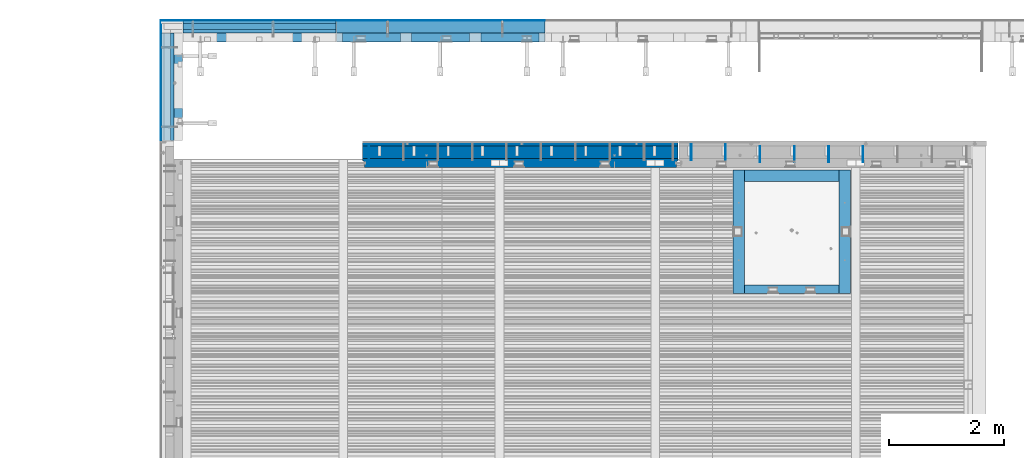
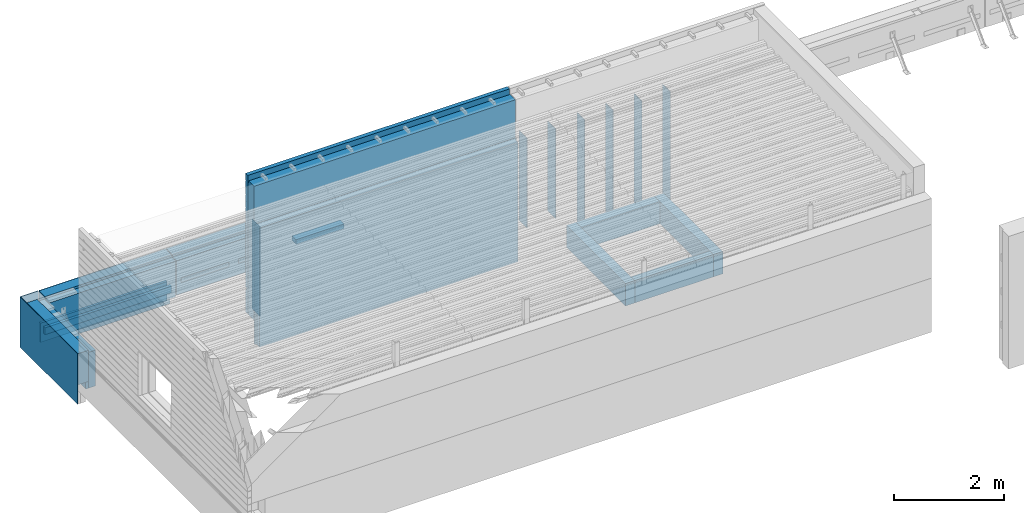
# One storey, part 79 of 153: 31 walls, 10 elements without a shape of their own.
"""IFC2X3 building model written with IfcOpenShell, lengths in millimetres."""

from ifc_helpers import new_model, si_unit, frame, origin_with_axes, place, context, subcontext, project, spatial, faceted_brep, material, type_object, element, aggregate, save


model = new_model("IFC2X3")

# Units and contexts
model_context = context("Model", 3, precision=1e-05, world=origin_with_axes())
body_context = subcontext(model_context, "Body", "Model", "MODEL_VIEW")
ifc_project = project(units=[si_unit("LENGTHUNIT", "METRE", prefix="MILLI"), si_unit("AREAUNIT", "SQUARE_METRE"), si_unit("VOLUMEUNIT", "CUBIC_METRE"), si_unit("MASSUNIT", "GRAM", prefix="KILO"), si_unit("TIMEUNIT", "SECOND"), si_unit("PLANEANGLEUNIT", "RADIAN"), si_unit("SOLIDANGLEUNIT", "STERADIAN"), si_unit("THERMODYNAMICTEMPERATUREUNIT", "DEGREE_CELSIUS"), si_unit("LUMINOUSINTENSITYUNIT", "LUMEN")], contexts=[model_context])

# Site, building, storey
site_placement = place(None, origin_with_axes())
site = spatial("IfcSite", under=ifc_project, at=site_placement, CompositionType="ELEMENT")
building_placement = place(site_placement, origin_with_axes())
building = spatial("IfcBuilding", under=site, at=building_placement, CompositionType="ELEMENT")
storey_placement = place(building_placement, origin_with_axes())
storey = spatial("IfcBuildingStorey", under=building, at=storey_placement, Name="8", CompositionType="ELEMENT", Elevation=0.0)

# Assembly, walls
assembly_1_placement = place(storey_placement, origin_with_axes())
assembly_1 = element("IfcElementAssembly", 1, at=assembly_1_placement, inside=storey, AssemblyPlace="NOTDEFINED", PredefinedType="REINFORCEMENT_UNIT")
ifc_material_1 = material(Name="Undefined")
wall_type_1 = type_object("IfcWallType", PredefinedType="NOTDEFINED")
wall_1_placement = place(assembly_1_placement, frame((19880.0500042038, 20799.9500000001, 104075.0), z_axis=(0.0, 0.0, 1.0), x_axis=(0.0, -1.0, 0.0)))
wall_1 = element("IfcWall", 2, at=wall_1_placement, type_object=wall_type_1, material=ifc_material_1, Name="(PD)", context=body_context, shape_type="Brep", body=[
    faceted_brep([(0.0, 5.0, -1265.0), (0.0, 5.0, 1265.0), (280.000000000011, 5.0, 1265.0), (280.000000000011, 5.0, -1265.0), (0.0, -5.0, 1265.0), (280.000000000011, -5.0, 1265.0), (0.0, -5.0, -1265.0), (280.000000000011, -5.0, -1265.0)], [[[0, 1, 2, 3]], [[1, 4, 5, 2]], [[4, 6, 7, 5]], [[6, 0, 3, 7]], [[5, 7, 3, 2]], [[6, 4, 1, 0]]]),
])
wall_2_placement = place(assembly_1_placement, frame((19280.0500042038, 20799.9500000001, 104075.0), z_axis=(0.0, 0.0, 1.0), x_axis=(0.0, -1.0, 0.0)))
wall_2 = element("IfcWall", 3, at=wall_2_placement, type_object=wall_type_1, material=ifc_material_1, Name="(PD)", context=body_context, shape_type="Brep", body=[
    faceted_brep([(0.0, 5.0, -1265.0), (0.0, 5.0, 1265.0), (280.000000000011, 5.0, 1265.0), (280.000000000011, 5.0, -1265.0), (0.0, -5.0, 1265.0), (280.000000000011, -5.0, 1265.0), (0.0, -5.0, -1265.0), (280.000000000011, -5.0, -1265.0)], [[[0, 1, 2, 3]], [[1, 4, 5, 2]], [[4, 6, 7, 5]], [[6, 0, 3, 7]], [[5, 7, 3, 2]], [[6, 4, 1, 0]]]),
])
wall_3_placement = place(assembly_1_placement, frame((18680.0500042038, 20799.9500000001, 104075.0), z_axis=(0.0, 0.0, 1.0), x_axis=(0.0, -1.0, 0.0)))
wall_3 = element("IfcWall", 4, at=wall_3_placement, type_object=wall_type_1, material=ifc_material_1, Name="(PD)", context=body_context, shape_type="Brep", body=[
    faceted_brep([(0.0, 5.0, -1265.0), (0.0, 5.0, 1265.0), (280.000000000011, 5.0, 1265.0), (280.000000000011, 5.0, -1265.0), (0.0, -5.0, 1265.0), (280.000000000011, -5.0, 1265.0), (0.0, -5.0, -1265.0), (280.000000000011, -5.0, -1265.0)], [[[0, 1, 2, 3]], [[1, 4, 5, 2]], [[4, 6, 7, 5]], [[6, 0, 3, 7]], [[5, 7, 3, 2]], [[6, 4, 1, 0]]]),
])
wall_4_placement = place(assembly_1_placement, frame((18080.0500042038, 20799.9500000001, 104075.0), z_axis=(0.0, 0.0, 1.0), x_axis=(0.0, -1.0, 0.0)))
wall_4 = element("IfcWall", 5, at=wall_4_placement, type_object=wall_type_1, material=ifc_material_1, Name="(PD)", context=body_context, shape_type="Brep", body=[
    faceted_brep([(0.0, 5.0, -1265.0), (0.0, 5.0, 1265.0), (280.000000000011, 5.0, 1265.0), (280.000000000011, 5.0, -1265.0), (0.0, -5.0, 1265.0), (280.000000000011, -5.0, 1265.0), (0.0, -5.0, -1265.0), (280.000000000011, -5.0, -1265.0)], [[[0, 1, 2, 3]], [[1, 4, 5, 2]], [[4, 6, 7, 5]], [[6, 0, 3, 7]], [[5, 7, 3, 2]], [[6, 4, 1, 0]]]),
])

# Assembly, wall
assembly_2_placement = place(storey_placement, origin_with_axes())
assembly_2 = element("IfcElementAssembly", 6, at=assembly_2_placement, inside=storey, AssemblyPlace="NOTDEFINED", PredefinedType="REINFORCEMENT_UNIT")
ifc_material_2 = material(Name="CONCRETE/C25/30")
wall_type_2 = type_object("IfcWallType", PredefinedType="NOTDEFINED")
wall_5_placement = place(assembly_2_placement, frame((7819.99893035864, 22770.0019145493, 102800.0), z_axis=(0.0, 0.0, 1.0), x_axis=(0.0, -1.0, 0.0)))
wall_5 = element("IfcWall", 7, at=wall_5_placement, type_object=wall_type_2, material=ifc_material_2, context=body_context, shape_type="Brep", body=[
    faceted_brep([(9.09494701772928e-13, 30.0000000000036, -75.0), (9.09494701772928e-13, 30.0000000000036, 75.0), (1870.0020093227, 30.0000000000009, 75.0), (1870.0020093227, 30.0000000000009, -75.0), (9.09494701772928e-13, -29.9999999999964, 75.0), (1870.0020093227, -29.9999999999991, 75.0), (9.09494701772928e-13, -29.9999999999964, -75.0), (1870.0020093227, -29.9999999999991, -75.0)], [[[0, 1, 2, 3]], [[1, 4, 5, 2]], [[4, 6, 7, 5]], [[6, 0, 3, 7]], [[5, 7, 3, 2]], [[6, 4, 1, 0]]]),
])

# Assembly, walls
assembly_3_placement = place(storey_placement, origin_with_axes())
assembly_3 = element("IfcElementAssembly", 8, at=assembly_3_placement, inside=storey, AssemblyPlace="NOTDEFINED", PredefinedType="REINFORCEMENT_UNIT")
wall_6_placement = place(assembly_3_placement, frame((10677.5, 22800.0, 102800.0), z_axis=(0.0, 0.0, 1.0), x_axis=(-1.0, 3.00000001838171e-08, 0.0)))
wall_6 = element("IfcWall", 9, at=wall_6_placement, type_object=wall_type_2, material=ifc_material_2, context=body_context, shape_type="Brep", body=[
    faceted_brep([(9.09494701772928e-13, 30.0000000000036, -75.0), (9.09494701772928e-13, 30.0000000000036, 75.0), (2662.5, 30.0, 75.0), (2662.5, 30.0, -75.0), (9.09494701772928e-13, -29.9999999999964, 75.0), (2662.5, -30.0, 75.0), (9.09494701772928e-13, -29.9999999999964, -75.0), (2662.5, -30.0, -75.0)], [[[0, 1, 2, 3]], [[1, 4, 5, 2]], [[4, 6, 7, 5]], [[6, 0, 3, 7]], [[5, 7, 3, 2]], [[6, 4, 1, 0]]]),
])
wall_type_3 = type_object("IfcWallType", PredefinedType="NOTDEFINED")
wall_7_placement = place(assembly_3_placement, frame((10677.5, 22885.0, 102660.0), z_axis=(0.0, 0.0, 1.0), x_axis=(-1.0, 3.00000001838171e-08, 0.0)))
wall_7 = element("IfcWall", 10, at=wall_7_placement, type_object=wall_type_3, material=ifc_material_2, context=body_context, shape_type="Brep", body=[
    faceted_brep([(9.09494701772928e-13, 55.0, -215.0), (9.09494701772928e-13, 55.0, 215.0), (2662.50000000001, 55.0, 215.0), (2662.50000000001, 55.0, -215.0), (0.0, -55.0, 215.0), (2662.50000000001, -55.0, 215.0), (0.0, -55.0, -215.0), (2662.50000000001, -55.0, -215.0)], [[[0, 1, 2, 3]], [[1, 4, 5, 2]], [[4, 6, 7, 5]], [[6, 0, 3, 7]], [[5, 7, 3, 2]], [[6, 4, 1, 0]]]),
])
ifc_material_3 = material()
wall_type_4 = type_object("IfcWallType", PredefinedType="NOTDEFINED")
wall_8_placement = place(assembly_3_placement, frame((10677.5, 22965.0, 102660.0), z_axis=(0.0, 0.0, 1.0), x_axis=(-1.0, 3.00000001838171e-08, 0.0)))
wall_8 = element("IfcWall", 11, at=wall_8_placement, type_object=wall_type_4, material=ifc_material_3, context=body_context, shape_type="Brep", body=[
    faceted_brep([(-9.09494701772928e-13, 25.0, -215.0), (-9.09494701772928e-13, 25.0, 215.0), (2662.5, 25.0, 215.0), (2662.5, 25.0, -215.0), (-9.09494701772928e-13, -25.0000000000036, 215.0), (2662.5, -25.0, 215.0), (-9.09494701772928e-13, -25.0000000000036, -215.0), (2662.5, -25.0, -215.0)], [[[0, 1, 2, 3]], [[1, 4, 5, 2]], [[4, 6, 7, 5]], [[6, 0, 3, 7]], [[5, 7, 3, 2]], [[6, 4, 1, 0]]]),
])

# Wall
wall_type_5 = type_object("IfcWallType", PredefinedType="NOTDEFINED")
wall_9_placement = place(assembly_1_placement, frame((17480.0500042038, 20829.9500000001, 104340.0), z_axis=(0.0, 0.0, 1.0), x_axis=(0.0, -1.0, 0.0)))
wall_9 = element("IfcWall", 12, at=wall_9_placement, type_object=wall_type_5, material=ifc_material_1, Name="(PD)", context=body_context, shape_type="Brep", body=[
    faceted_brep([(0.0, 5.0, -1000.0), (0.0, 5.0, 1000.0), (280.000000000011, 5.0, 1000.0), (280.000000000011, 5.0, -1000.0), (0.0, -5.0, 1000.0), (280.000000000011, -5.0, 1000.0), (0.0, -5.0, -1000.0), (280.000000000011, -5.0, -1000.0)], [[[0, 1, 2, 3]], [[1, 4, 5, 2]], [[4, 6, 7, 5]], [[6, 0, 3, 7]], [[5, 7, 3, 2]], [[6, 4, 1, 0]]]),
])

wall_10_placement = place(assembly_1_placement, frame((16880.0500042038, 20829.9500000001, 104340.0), z_axis=(0.0, 0.0, 1.0), x_axis=(0.0, -1.0, 0.0)))
wall_10 = element("IfcWall", 13, at=wall_10_placement, type_object=wall_type_5, material=ifc_material_1, Name="(PD)", context=body_context, shape_type="Brep", body=[
    faceted_brep([(0.0, 5.0, -1000.0), (0.0, 5.0, 1000.0), (280.000000000011, 5.0, 1000.0), (280.000000000011, 5.0, -1000.0), (0.0, -5.0, 1000.0), (280.000000000011, -5.0, 1000.0), (0.0, -5.0, -1000.0), (280.000000000011, -5.0, -1000.0)], [[[0, 1, 2, 3]], [[1, 4, 5, 2]], [[4, 6, 7, 5]], [[6, 0, 3, 7]], [[5, 7, 3, 2]], [[6, 4, 1, 0]]]),
])

aggregate(assembly_1, [wall_1, wall_2, wall_3, wall_4, wall_9, wall_10])

# Assemblies, wall
assembly_4_placement = place(storey_placement, origin_with_axes())
assembly_4 = element("IfcElementAssembly", 14, at=assembly_4_placement, inside=storey, AssemblyPlace="NOTDEFINED", PredefinedType="REINFORCEMENT_UNIT")
assembly_5_placement = place(assembly_4_placement, origin_with_axes())
assembly_5 = element("IfcElementAssembly", 15, at=assembly_5_placement, Name="Steel Assembly", AssemblyPlace="NOTDEFINED", PredefinedType="NOTDEFINED")
wall_11_placement = place(assembly_5_placement, frame((11260.0500042038, 20829.9500000001, 104340.0), z_axis=(0.0, 0.0, 1.0), x_axis=(0.0, -1.0, 0.0)))
wall_11 = element("IfcWall", 16, at=wall_11_placement, type_object=wall_type_5, material=ifc_material_1, Name="(PD)", context=body_context, shape_type="Brep", body=[
    faceted_brep([(0.0, 5.0, -1000.0), (0.0, 5.0, 1000.0), (280.000000000011, 5.0, 1000.0), (280.000000000011, 5.0, -1000.0), (0.0, -5.0, 1000.0), (280.000000000011, -5.0, 1000.0), (0.0, -5.0, -1000.0), (280.000000000011, -5.0, -1000.0)], [[[0, 1, 2, 3]], [[1, 4, 5, 2]], [[4, 6, 7, 5]], [[6, 0, 3, 7]], [[5, 7, 3, 2]], [[6, 4, 1, 0]]]),
])
aggregate(assembly_5, [wall_11])

# Assemblies, walls
assembly_6_placement = place(storey_placement, origin_with_axes())
assembly_6 = element("IfcElementAssembly", 17, at=assembly_6_placement, inside=storey, AssemblyPlace="NOTDEFINED", PredefinedType="REINFORCEMENT_UNIT")
assembly_7_placement = place(assembly_6_placement, origin_with_axes())
assembly_7 = element("IfcElementAssembly", 18, at=assembly_7_placement, Name="Steel Assembly", AssemblyPlace="NOTDEFINED", PredefinedType="NOTDEFINED")
wall_type_6 = type_object("IfcWallType", PredefinedType="NOTDEFINED")
wall_12_placement = place(assembly_7_placement, frame((10692.5, 22880.0, 103162.5), z_axis=(0.0, 0.0, 1.0), x_axis=(1.0, 0.0, 0.0)))
wall_12 = element("IfcWall", 19, at=wall_12_placement, type_object=wall_type_6, material=ifc_material_3, context=body_context, shape_type="Brep", body=[
    faceted_brep([(0.0, 110.0, -407.5), (0.0, 110.0, 407.5), (3632.5, 110.0, 407.5), (3632.5, 110.0, -407.5), (0.0, -110.0, 407.5), (3632.5, -110.0, 407.5), (0.0, -110.0, -407.5), (3632.5, -110.0, -407.5)], [[[0, 1, 2, 3]], [[1, 4, 5, 2]], [[4, 6, 7, 5]], [[6, 0, 3, 7]], [[5, 7, 3, 2]], [[6, 4, 1, 0]]]),
])
aggregate(assembly_7, [wall_12])
ifc_material_4 = material()
wall_type_7 = type_object("IfcWallType", PredefinedType="NOTDEFINED")
wall_13_placement = place(assembly_6_placement, frame((10692.5, 22995.0, 103162.5), z_axis=(0.0, 0.0, 1.0), x_axis=(1.0, 0.0, 0.0)))
wall_13 = element("IfcWall", 20, at=wall_13_placement, type_object=wall_type_7, material=ifc_material_4, context=body_context, shape_type="Brep", body=[
    faceted_brep([(0.0, 5.0, -407.5), (0.0, 5.0, 407.5), (3632.5, 5.0, 407.5), (3632.5, 5.0, -407.5), (0.0, -5.0, 407.5), (3632.5, -5.0, 407.5), (0.0, -5.0, -407.5), (3632.5, -5.0, -407.5)], [[[0, 1, 2, 3]], [[1, 4, 5, 2]], [[4, 6, 7, 5]], [[6, 0, 3, 7]], [[5, 7, 3, 2]], [[6, 4, 1, 0]]]),
])
ifc_material_5 = material(Name="EPS")
wall_type_8 = type_object("IfcWallType", PredefinedType="NOTDEFINED")
wall_14_placement = place(assembly_6_placement, frame((13212.5, 22695.0, 103055.0), z_axis=(0.0, 1.0, 0.0), x_axis=(1.0, 0.0, 0.0)))
wall_14 = element("IfcWall", 21, at=wall_14_placement, type_object=wall_type_8, material=ifc_material_5, context=body_context, shape_type="Brep", body=[
    faceted_brep([(0.0, 50.0, -75.0), (0.0, 50.0, 75.0), (1010.00000000001, 50.0, 75.0), (1010.00000000001, 50.0, -75.0), (0.0, -50.0, 75.0), (1010.00000000001, -50.0, 75.0), (0.0, -50.0, -75.0), (1010.00000000001, -50.0, -75.0)], [[[0, 1, 2, 3]], [[1, 4, 5, 2]], [[4, 6, 7, 5]], [[6, 0, 3, 7]], [[5, 7, 3, 2]], [[6, 4, 1, 0]]]),
])
wall_15_placement = place(assembly_6_placement, frame((12002.5, 22695.0, 103055.0), z_axis=(0.0, 1.0, 0.0), x_axis=(1.0, 0.0, 0.0)))
wall_15 = element("IfcWall", 22, at=wall_15_placement, type_object=wall_type_8, material=ifc_material_5, context=body_context, shape_type="Brep", body=[
    faceted_brep([(0.0, 50.0, -75.0), (0.0, 50.0, 75.0), (1010.00000000001, 50.0, 75.0), (1010.00000000001, 50.0, -75.0), (0.0, -50.0, 75.0), (1010.00000000001, -50.0, 75.0), (0.0, -50.0, -75.0), (1010.00000000001, -50.0, -75.0)], [[[0, 1, 2, 3]], [[1, 4, 5, 2]], [[4, 6, 7, 5]], [[6, 0, 3, 7]], [[5, 7, 3, 2]], [[6, 4, 1, 0]]]),
])
wall_16_placement = place(assembly_6_placement, frame((10792.5, 22695.0, 103055.0), z_axis=(0.0, 1.0, 0.0), x_axis=(1.0, 0.0, 0.0)))
wall_16 = element("IfcWall", 23, at=wall_16_placement, type_object=wall_type_8, material=ifc_material_5, context=body_context, shape_type="Brep", body=[
    faceted_brep([(0.0, 50.0, -75.0), (0.0, 50.0, 75.0), (1010.00000000001, 50.0, 75.0), (1010.00000000001, 50.0, -75.0), (0.0, -50.0, 75.0), (1010.00000000001, -50.0, 75.0), (0.0, -50.0, -75.0), (1010.00000000001, -50.0, -75.0)], [[[0, 1, 2, 3]], [[1, 4, 5, 2]], [[4, 6, 7, 5]], [[6, 0, 3, 7]], [[5, 7, 3, 2]], [[6, 4, 1, 0]]]),
])

# Wall
wall_type_9 = type_object("IfcWallType", PredefinedType="NOTDEFINED")
wall_17_placement = place(assembly_4_placement, frame((11147.5, 20505.0, 104082.5), z_axis=(0.0, 0.0, 1.0), x_axis=(1.0, 0.0, 0.0)))
wall_17 = element("IfcWall", 24, at=wall_17_placement, type_object=wall_type_9, material=ifc_material_2, context=body_context, shape_type="Brep", body=[
    faceted_brep([(5475.0, -75.0, 1327.5), (5475.0, -75.0, -1327.5), (5475.0, 25.0, -1327.5), (5475.0, 25.0, 1327.5), (5505.0, 45.0, 1327.5), (5505.0, 45.0, -1327.5), (29.9999989349526, 25.0000007100352, 1327.5), (29.9999989349526, 25.0000007100352, -1327.5), (30.0000010509684, -75.0, -1327.5), (30.0000010509684, -75.0, 1327.5), (0.0, 45.0, 1327.5), (0.0, 45.0, -1327.5), (0.0, 75.0, 1327.5), (0.0, 75.0, -1327.5), (5505.0, 75.0, 1327.5), (5505.0, 75.0, -1327.5)], [[[0, 1, 2, 3]], [[4, 3, 2, 5]], [[6, 7, 8, 9]], [[10, 11, 7, 6]], [[12, 13, 11, 10]], [[13, 12, 14, 15]], [[15, 14, 4, 5]], [[1, 8, 7, 11, 13, 15, 5, 2]], [[9, 8, 1, 0]], [[14, 12, 10, 6, 9, 0, 3, 4]]]),
])

ifc_material_6 = material(Name="COS5gt")
wall_type_10 = type_object("IfcWallType", PredefinedType="NOTDEFINED")
wall_18_placement = place(assembly_4_placement, frame((11147.5, 20690.0, 104767.5), z_axis=(0.0, 0.0, 1.0), x_axis=(1.0, 0.0, 0.0)))
wall_18 = element("IfcWall", 25, at=wall_18_placement, type_object=wall_type_10, material=ifc_material_6, context=body_context, shape_type="Brep", body=[
    faceted_brep([(5505.0, 90.0, -1487.5), (0.0, 90.0, -1487.5), (0.0, 90.0, -1437.5), (5505.0, 90.0, -1437.5), (5505.0, 110.0, -1437.5), (0.0, 110.0, -1437.5), (0.0, -110.0, 1487.5), (0.0, -110.0, -1487.5), (5505.0, -110.0, -1487.5), (5505.0, -110.0, 1487.5), (5505.0, 90.0, 1487.5), (0.0, 90.0, 1487.5), (5505.0, 90.0, 1437.5), (0.0, 90.0, 1437.5), (5505.0, 110.0, 1437.5), (0.0, 110.0, 1437.5)], [[[0, 1, 2, 3]], [[4, 3, 2, 5]], [[6, 7, 8, 9]], [[6, 9, 10, 11]], [[10, 12, 13, 11]], [[14, 15, 13, 12]], [[15, 14, 4, 5]], [[1, 7, 6, 11, 13, 15, 5, 2]], [[8, 7, 1, 0]], [[14, 12, 10, 9, 8, 0, 3, 4]]]),
])

ifc_material_7 = material(Name="CONCRETE/C30/37")
wall_type_11 = type_object("IfcWallType", PredefinedType="NOTDEFINED")
wall_19_placement = place(assembly_4_placement, frame((11147.5, 20842.5, 104822.5), z_axis=(0.0, 0.0, 1.0), x_axis=(1.0, 0.0, 0.0)))
wall_19 = element("IfcWall", 26, at=wall_19_placement, type_object=wall_type_11, material=ifc_material_7, context=body_context, shape_type="Brep", body=[
    faceted_brep([(5505.0, 42.5, -1042.50000011071), (0.0, 42.5, -1042.50000011071), (7.27595761418343e-12, 12.4999999999854, -1042.50000011071), (5505.0, 12.4999999999854, -1042.50000011071), (7.27595761418343e-12, 12.4999999999854, -992.500000110711), (5505.0, 12.4999999999854, -992.500000110711), (5505.0, 42.4999999999854, -992.500000110711), (0.0, 42.5, -992.500000110711), (0.0, -42.5, -1542.5), (0.0, 42.5, -1542.5), (5505.0, 42.5, -1542.5), (5505.0, -42.5, -1542.5), (0.0, -42.5, 1542.5), (5505.0, -42.5, 1542.5), (0.0, 42.5, 1542.5), (5505.0, 42.5, 1542.5), (5505.0, 42.4999992423946, 1381.99999988925), (0.0, 42.5, 1381.99999988925), (5505.0, 32.4999991119257, 1380.00000040043), (0.0, 32.4999991119257, 1380.00000040043), (5505.0, 32.4999992499324, 1369.9999999992), (0.0, 32.4999992499324, 1369.9999999992), (5505.0, 42.5, 1367.99999994476), (0.0, 42.5, 1367.99999994476), (5505.0, 42.4999992423946, 1231.99999988925), (0.0, 42.5, 1231.99999988925), (5505.0, 32.4999991119257, 1230.00000040043), (0.0, 32.4999991119257, 1230.00000040043), (5505.0, 32.4999992499324, 1219.9999999992), (0.0, 32.4999992499324, 1219.9999999992), (5505.0, 42.5, 1217.99999994476), (0.0, 42.5, 1217.99999994476), (5505.0, 42.4999992423946, 1081.99999988925), (0.0, 42.5, 1081.99999988925), (5505.0, 32.4999991119257, 1080.00000040043), (0.0, 32.4999991119257, 1080.00000040043), (5505.0, 32.4999992499324, 1069.9999999992), (0.0, 32.4999992499324, 1069.9999999992), (5505.0, 42.5, 1067.99999994476), (0.0, 42.5, 1067.99999994476), (5505.0, 42.4999992423946, 931.999999889245), (0.0, 42.5, 931.999999889245), (5505.0, 32.4999991119257, 930.000000400425), (0.0, 32.4999991119257, 930.000000400425), (5505.0, 32.4999992499324, 919.9999999992), (0.0, 32.4999992499324, 919.9999999992), (5505.0, 42.5, 917.999999944761), (0.0, 42.5, 917.999999944761), (5505.0, 42.4999992423946, 781.999999889245), (0.0, 42.5, 781.999999889245), (5505.0, 32.4999991119257, 780.000000400425), (0.0, 32.4999992501716, 779.999999999243), (5505.0, 32.4999992499324, 769.9999999992), (0.0, 32.4999992499324, 769.9999999992), (5505.0, 42.5, 767.999999944761), (0.0, 42.5, 767.999999944761), (5505.0, 42.4999992423946, 631.999999889245), (0.0, 42.5, 631.999999889245), (5505.0, 32.4999991119257, 630.000000400425), (0.0, 32.4999991119257, 630.000000400425), (5505.0, 32.4999992499324, 619.9999999992), (0.0, 32.4999992499324, 619.9999999992), (5505.0, 42.5, 617.999999944761), (0.0, 42.5, 617.999999944761), (5505.0, 42.4999992423946, 481.999999889245), (0.0, 42.5, 481.999999889245), (5505.0, 32.4999991119257, 480.000000400425), (0.0, 32.4999992501716, 479.999999999243), (5505.0, 32.4999992499324, 469.9999999992), (1.81898940354586e-12, 32.4999992499324, 469.9999999992), (5505.0, 42.5, 467.999999944761), (0.0, 42.5, 467.999999944761), (5505.0, 42.4999992423946, 331.999999889245), (0.0, 42.5, 331.999999889245), (5505.0, 32.4999991119257, 330.000000400425), (0.0, 32.4999991119257, 330.000000400425), (5505.0, 32.4999992499324, 319.9999999992), (0.0, 32.4999992499324, 319.9999999992), (5505.0, 42.5, 317.999999944761), (0.0, 42.5, 317.999999944761), (5505.0, 42.4999992423946, 181.999999889245), (0.0, 42.5, 181.999999889245), (5505.0, 32.4999991119257, 180.000000400425), (0.0, 32.4999992501716, 179.999999999243), (5505.0, 32.4999992499324, 169.9999999992), (-1.81898940354586e-12, 32.4999992499324, 169.9999999992), (5505.0, 42.5, 167.999999944761), (0.0, 42.5, 167.999999944761), (5505.0, 42.4999992423946, 31.9999998892454), (0.0, 42.5, 31.9999998892454), (5505.0, 32.4999991119257, 30.0000004004251), (1.81898940354586e-12, 32.4999991119257, 30.0000004004251), (5505.0, 32.4999992499324, 19.9999999991996), (1.81898940354586e-12, 32.4999992499324, 19.9999999991996), (5505.0, 42.5, 17.9999999447609), (0.0, 42.5, 17.9999999447609), (5505.0, 42.4999992423946, -118.000000110755), (0.0, 42.5, -118.000000110755), (5505.0, 32.4999991119257, -119.999999599575), (0.0, 32.4999992501716, -120.000000000757), (5505.0, 32.4999992499324, -130.0000000008), (0.0, 32.4999992499324, -130.0000000008), (5505.0, 42.5, -132.000000055239), (0.0, 42.5, -132.000000055239), (5505.0, 42.4999992423946, -268.000000110755), (0.0, 42.5, -268.000000110755), (5505.0, 32.4999991119257, -269.999999599575), (0.0, 32.4999991119257, -269.999999599575), (5505.0, 32.4999992499324, -280.0000000008), (0.0, 32.4999992499324, -280.0000000008), (5505.0, 42.5, -282.000000055239), (0.0, 42.5, -282.000000055239), (5505.0, 42.4999992423946, -418.000000110755), (0.0, 42.5, -418.000000110755), (5505.0, 32.4999991119257, -419.999999599575), (0.0, 32.4999992501716, -420.000000000757), (5505.0, 32.4999992499324, -430.0000000008), (0.0, 32.4999992499324, -430.0000000008), (5505.0, 42.5, -432.000000055239), (0.0, 42.5, -432.000000055239), (5505.0, 42.4999992423946, -568.000000110755), (0.0, 42.5, -568.000000110755), (5505.0, 32.4999991119257, -569.999999599575), (0.0, 32.4999991119257, -569.999999599575), (5505.0, 32.4999992499324, -580.0000000008), (0.0, 32.4999992499324, -580.0000000008), (5505.0, 42.5, -582.000000055239), (0.0, 42.5, -582.000000055239), (5505.0, 42.4999992423946, -718.000000110755), (0.0, 42.5, -718.000000110755), (5505.0, 32.4999991119257, -719.999999599575), (0.0, 32.4999992501716, -720.000000000757), (5505.0, 32.4999992499324, -730.0000000008), (0.0, 32.4999992499324, -730.0000000008), (5505.0, 42.5, -732.000000055239), (0.0, 42.5, -732.000000055239), (5505.0, 42.4999992423946, -868.000000110755), (0.0, 42.5, -868.000000110755), (5505.0, 32.4999991119257, -869.999999599575), (0.0, 32.4999991119257, -869.999999599575), (5505.0, 32.4999992499324, -880.0000000008), (0.0, 32.4999992499324, -880.0000000008), (5505.0, 42.5, -882.000000055239), (0.0, 42.5, -882.000000055239)], [[[0, 1, 2, 3]], [[3, 2, 4, 5]], [[6, 5, 4, 7]], [[8, 9, 10, 11]], [[12, 8, 11, 13]], [[14, 12, 13, 15]], [[14, 15, 16, 17]], [[16, 18, 19, 17]], [[20, 21, 19, 18]], [[22, 23, 21, 20]], [[23, 22, 24, 25]], [[24, 26, 27, 25]], [[28, 29, 27, 26]], [[30, 31, 29, 28]], [[31, 30, 32, 33]], [[32, 34, 35, 33]], [[36, 37, 35, 34]], [[38, 39, 37, 36]], [[39, 38, 40, 41]], [[40, 42, 43, 41]], [[44, 45, 43, 42]], [[46, 47, 45, 44]], [[47, 46, 48, 49]], [[48, 50, 51, 49]], [[52, 53, 51, 50]], [[54, 55, 53, 52]], [[55, 54, 56, 57]], [[56, 58, 59, 57]], [[60, 61, 59, 58]], [[62, 63, 61, 60]], [[63, 62, 64, 65]], [[64, 66, 67, 65]], [[68, 69, 67, 66]], [[70, 71, 69, 68]], [[71, 70, 72, 73]], [[72, 74, 75, 73]], [[76, 77, 75, 74]], [[78, 79, 77, 76]], [[79, 78, 80, 81]], [[80, 82, 83, 81]], [[84, 85, 83, 82]], [[86, 87, 85, 84]], [[87, 86, 88, 89]], [[88, 90, 91, 89]], [[92, 93, 91, 90]], [[94, 95, 93, 92]], [[95, 94, 96, 97]], [[96, 98, 99, 97]], [[100, 101, 99, 98]], [[102, 103, 101, 100]], [[103, 102, 104, 105]], [[104, 106, 107, 105]], [[108, 109, 107, 106]], [[110, 111, 109, 108]], [[111, 110, 112, 113]], [[112, 114, 115, 113]], [[116, 117, 115, 114]], [[118, 119, 117, 116]], [[119, 118, 120, 121]], [[120, 122, 123, 121]], [[124, 125, 123, 122]], [[126, 127, 125, 124]], [[127, 126, 128, 129]], [[128, 130, 131, 129]], [[132, 133, 131, 130]], [[134, 135, 133, 132]], [[135, 134, 136, 137]], [[136, 138, 139, 137]], [[140, 141, 139, 138]], [[142, 143, 141, 140]], [[143, 142, 6, 7]], [[2, 1, 9, 8, 12, 14, 17, 19, 21, 23, 25, 27, 29, 31, 33, 35, 37, 39, 41, 43, 45, 47, 49, 51, 53, 55, 57, 59, 61, 63, 65, 67, 69, 71, 73, 75, 77, 79, 81, 83, 85, 87, 89, 91, 93, 95, 97, 99, 101, 103, 105, 107, 109, 111, 113, 115, 117, 119, 121, 123, 125, 127, 129, 131, 133, 135, 137, 139, 141, 143, 7, 4]], [[10, 9, 1, 0]], [[142, 140, 138, 136, 134, 132, 130, 128, 126, 124, 122, 120, 118, 116, 114, 112, 110, 108, 106, 104, 102, 100, 98, 96, 94, 92, 90, 88, 86, 84, 82, 80, 78, 76, 74, 72, 70, 68, 66, 64, 62, 60, 58, 56, 54, 52, 50, 48, 46, 44, 42, 40, 38, 36, 34, 32, 30, 28, 26, 24, 22, 20, 18, 16, 15, 13, 11, 10, 0, 3, 5, 6]]]),
])

aggregate(assembly_4, [assembly_5, wall_17, wall_18, wall_19])

# Assembly, wall
assembly_8_placement = place(assembly_2_placement, origin_with_axes())
assembly_8 = element("IfcElementAssembly", 27, at=assembly_8_placement, Name="Steel Assembly", AssemblyPlace="NOTDEFINED", PredefinedType="NOTDEFINED")
wall_type_12 = type_object("IfcWallType", PredefinedType="NOTDEFINED")
wall_20_placement = place(assembly_8_placement, frame((7739.99998962479, 20899.9998201732, 103222.5), z_axis=(0.0, 0.0, 1.0), x_axis=(0.0, 1.0, 0.0)))
wall_20 = element("IfcWall", 28, at=wall_20_placement, type_object=wall_type_12, material=ifc_material_3, context=body_context, shape_type="Brep", body=[
    faceted_brep([(-3.63797880709171e-12, 110.0, -347.5), (-3.63797880709171e-12, 110.0, 347.5), (1870.00203231127, 110.0, 347.5), (1870.00203231127, 110.0, -347.5), (-3.63797880709171e-12, -110.0, 347.5), (1870.00203231127, -110.0, 347.5), (-3.63797880709171e-12, -110.0, -347.5), (1870.00203231127, -110.0, -347.5)], [[[0, 1, 2, 3]], [[1, 4, 5, 2]], [[4, 6, 7, 5]], [[6, 0, 3, 7]], [[5, 7, 3, 2]], [[6, 4, 1, 0]]]),
])
aggregate(assembly_8, [wall_20])

assembly_9_placement = place(assembly_3_placement, origin_with_axes())
assembly_9 = element("IfcElementAssembly", 29, at=assembly_9_placement, Name="Steel Assembly", AssemblyPlace="NOTDEFINED", PredefinedType="NOTDEFINED")
wall_21_placement = place(assembly_9_placement, frame((8015.0, 22880.0, 103222.5), z_axis=(0.0, 0.0, 1.0), x_axis=(1.0, 0.0, 0.0)))
wall_21 = element("IfcWall", 30, at=wall_21_placement, type_object=wall_type_12, material=ifc_material_3, context=body_context, shape_type="Brep", body=[
    faceted_brep([(-3.63797880709171e-12, 110.0, -347.5), (-3.63797880709171e-12, 110.0, 347.5), (2662.5, 110.0, 347.5), (2662.5, 110.0, -347.5), (-3.63797880709171e-12, -110.0, 347.5), (2662.5, -110.0, 347.5), (-3.63797880709171e-12, -110.0, -347.5), (2662.5, -110.0, -347.5)], [[[0, 1, 2, 3]], [[1, 4, 5, 2]], [[4, 6, 7, 5]], [[6, 0, 3, 7]], [[5, 7, 3, 2]], [[6, 4, 1, 0]]]),
])
aggregate(assembly_9, [wall_21])

# Wall
wall_type_13 = type_object("IfcWallType", PredefinedType="NOTDEFINED")
wall_22_placement = place(assembly_2_placement, frame((7619.99880283611, 22995.0017843993, 103007.5), z_axis=(0.0, 0.0, 1.0), x_axis=(1.0, 0.0, 0.0)))
wall_22 = element("IfcWall", 31, at=wall_22_placement, type_object=wall_type_13, material=ifc_material_4, context=body_context, shape_type="Brep", body=[
    faceted_brep([(380.00000000043, -5.0, 562.5), (380.00000000043, -5.0, -562.5), (380.000000000429, 5.00000000000364, -562.5), (380.000000000429, 5.00000000000364, 562.5), (9.99999999900137, -5.0, 562.5), (9.99999999900137, -5.0, -562.5), (0.0, 5.00000000000364, -562.5), (0.0, 5.00000000000364, 562.5)], [[[0, 1, 2, 3]], [[1, 0, 4, 5]], [[2, 1, 5, 6]], [[3, 2, 6, 7]], [[0, 3, 7, 4]], [[6, 5, 4, 7]]]),
])

wall_23_placement = place(assembly_2_placement, frame((7624.99998962452, 20899.9997400087, 103007.5), z_axis=(0.0, 0.0, 1.0), x_axis=(0.0, 1.0, 0.0)))
wall_23 = element("IfcWall", 32, at=wall_23_placement, type_object=wall_type_13, material=ifc_material_4, context=body_context, shape_type="Brep", body=[
    faceted_brep([(0.0, -4.99999999999636, -562.5), (0.0, -4.99999999999636, 562.5), (0.0, 5.00000000000364, 562.5), (0.0, 5.00000000000364, -562.5), (2090.00204622328, -4.99999999999909, 562.5), (2100.00204722345, 5.0, 562.5), (2100.00204722345, 5.0, -562.5), (2090.00204622328, -4.99999999999909, -562.5)], [[[0, 1, 2, 3]], [[2, 1, 4, 5]], [[3, 2, 5, 6]], [[0, 3, 6, 7]], [[1, 0, 7, 4]], [[6, 5, 4, 7]]]),
])

wall_24_placement = place(assembly_3_placement, frame((8015.0, 22995.0, 103007.5), z_axis=(0.0, 0.0, 1.0), x_axis=(1.0, 0.0, 0.0)))
wall_24 = element("IfcWall", 33, at=wall_24_placement, type_object=wall_type_13, material=ifc_material_4, context=body_context, shape_type="Brep", body=[
    faceted_brep([(0.0, 5.00000000000364, -562.5), (0.0, 5.00000000000364, 562.5), (2662.5, 5.0, 562.5), (2662.5, 5.0, -562.5), (0.0, -4.99999999999636, 562.5), (2662.5, -5.0, 562.5), (0.0, -4.99999999999636, -562.5), (2662.5, -5.0, -562.5)], [[[0, 1, 2, 3]], [[1, 4, 5, 2]], [[4, 6, 7, 5]], [[6, 0, 3, 7]], [[5, 7, 3, 2]], [[6, 4, 1, 0]]]),
])

wall_type_14 = type_object("IfcWallType", PredefinedType="NOTDEFINED")
wall_25_placement = place(assembly_2_placement, frame((7924.99999999978, 20899.9999481269, 103122.5), z_axis=(0.0, 0.0, 1.0), x_axis=(0.0, 1.0, 0.0)))
wall_25 = element("IfcWall", 34, at=wall_25_placement, type_object=wall_type_14, material=ifc_material_2, context=body_context, shape_type="Brep", body=[
    faceted_brep([(0.0, 75.0000000000036, -397.5), (0.0, 75.0000000000036, 397.5), (1870.00200932269, 75.0, 397.5), (1870.00200932269, 75.0, -397.5), (0.0, -75.0, 397.5), (1870.00200932269, -75.0000000000018, 397.5), (0.0, -75.0, -397.5), (1870.00200932269, -75.0000000000018, -397.5)], [[[0, 1, 2, 3]], [[1, 4, 5, 2]], [[4, 6, 7, 5]], [[6, 0, 3, 7]], [[5, 7, 3, 2]], [[6, 4, 1, 0]]]),
])

aggregate(assembly_2, [assembly_8, wall_5, wall_22, wall_23, wall_25])

wall_26_placement = place(assembly_3_placement, frame((8015.0, 22695.0, 103122.5), z_axis=(0.0, 0.0, 1.0), x_axis=(1.0, 0.0, 0.0)))
wall_26 = element("IfcWall", 35, at=wall_26_placement, type_object=wall_type_14, material=ifc_material_2, context=body_context, shape_type="Brep", body=[
    faceted_brep([(0.0, 75.0000000000036, -397.5), (0.0, 75.0000000000036, 397.5), (2662.5, 75.0, 397.5), (2662.5, 75.0, -397.5), (0.0, -75.0, 397.5), (2662.5, -75.0, 397.5), (0.0, -75.0, -397.5), (2662.5, -75.0, -397.5)], [[[0, 1, 2, 3]], [[1, 4, 5, 2]], [[4, 6, 7, 5]], [[6, 0, 3, 7]], [[5, 7, 3, 2]], [[6, 4, 1, 0]]]),
])

aggregate(assembly_3, [wall_7, wall_6, wall_8, assembly_9, wall_24, wall_26])

# Assembly, walls
assembly_10_placement = place(storey_placement, origin_with_axes())
assembly_10 = element("IfcElementAssembly", 36, at=assembly_10_placement, inside=storey, AssemblyPlace="NOTDEFINED", PredefinedType="REINFORCEMENT_UNIT")
wall_type_15 = type_object("IfcWallType", PredefinedType="NOTDEFINED")
wall_27_placement = place(assembly_10_placement, frame((17809.9999105288, 20280.0000293051, 103002.5), z_axis=(0.0, 0.0, 1.0), x_axis=(1.0, 0.0, 0.0)))
wall_27 = element("IfcWall", 37, at=wall_27_placement, type_object=wall_type_15, material=ifc_material_2, context=body_context, shape_type="Brep", body=[
    faceted_brep([(0.0, 100.0, -247.5), (0.0, 100.0, 247.5), (1649.99977111816, 100.0, 247.5), (1649.99977111816, 100.0, -247.5), (0.0, -100.0, 247.5), (1649.99977111816, -100.0, 247.5), (0.0, -100.0, -247.5), (1649.99977111816, -100.0, -247.5)], [[[0, 1, 2, 3]], [[1, 4, 5, 2]], [[4, 6, 7, 5]], [[6, 0, 3, 7]], [[5, 7, 3, 2]], [[6, 4, 1, 0]]]),
])
wall_28_placement = place(assembly_10_placement, frame((17710.0, 18229.9992663657, 103002.5), z_axis=(0.0, 0.0, 1.0), x_axis=(0.0, 1.0, 0.0)))
wall_28 = element("IfcWall", 38, at=wall_28_placement, type_object=wall_type_15, material=ifc_material_2, context=body_context, shape_type="Brep", body=[
    faceted_brep([(0.0, 100.0, -247.5), (0.0, 100.0, 247.5), (2150.00073363432, 100.0, 247.5), (2150.00073363432, 100.0, -247.5), (0.0, -100.0, 247.5), (2150.00073363432, -100.0, 247.5), (0.0, -100.0, -247.5), (2150.00073363432, -100.0, -247.5)], [[[0, 1, 2, 3]], [[1, 4, 5, 2]], [[4, 6, 7, 5]], [[6, 0, 3, 7]], [[5, 7, 3, 2]], [[6, 4, 1, 0]]]),
])
wall_29_placement = place(assembly_10_placement, frame((19559.999681647, 18229.9992663657, 103002.5), z_axis=(0.0, 0.0, 1.0), x_axis=(0.0, 1.0, 0.0)))
wall_29 = element("IfcWall", 39, at=wall_29_placement, type_object=wall_type_15, material=ifc_material_2, context=body_context, shape_type="Brep", body=[
    faceted_brep([(0.0, 100.0, -247.5), (0.0, 100.0, 247.5), (2150.00073363432, 100.0, 247.5), (2150.00073363432, 100.0, -247.5), (0.0, -100.0, 247.5), (2150.00073363432, -100.0, 247.5), (0.0, -100.0, -247.5), (2150.00073363432, -100.0, -247.5)], [[[0, 1, 2, 3]], [[1, 4, 5, 2]], [[4, 6, 7, 5]], [[6, 0, 3, 7]], [[5, 7, 3, 2]], [[6, 4, 1, 0]]]),
])
wall_type_16 = type_object("IfcWallType", PredefinedType="NOTDEFINED")
wall_30_placement = place(assembly_10_placement, frame((17809.9999105288, 18304.9992663657, 103002.5), z_axis=(0.0, 0.0, 1.0), x_axis=(1.0, 0.0, 0.0)))
wall_30 = element("IfcWall", 40, at=wall_30_placement, type_object=wall_type_16, material=ifc_material_2, context=body_context, shape_type="Brep", body=[
    faceted_brep([(0.0, 75.0, -247.5), (0.0, 75.0, 247.5), (1649.99961853027, 75.0, 247.5), (1649.99961853027, 75.0, -247.5), (0.0, -75.0, 247.5), (1649.99961853027, -75.0, 247.5), (0.0, -75.0, -247.5), (1649.99961853027, -75.0, -247.5)], [[[0, 1, 2, 3]], [[1, 4, 5, 2]], [[4, 6, 7, 5]], [[6, 0, 3, 7]], [[5, 7, 3, 2]], [[6, 4, 1, 0]]]),
])
aggregate(assembly_10, [wall_27, wall_30, wall_28, wall_29])

# Wall
wall_type_17 = type_object("IfcWallType", PredefinedType="NOTDEFINED")
wall_31_placement = place(assembly_6_placement, frame((10692.5, 22695.0, 103137.5), z_axis=(0.0, 0.0, 1.0), x_axis=(1.0, 0.0, 0.0)))
wall_31 = element("IfcWall", 41, at=wall_31_placement, type_object=wall_type_17, material=ifc_material_2, context=body_context, shape_type="Brep", body=[
    faceted_brep([(2520.0, 75.0000000000073, -32.4999999999854), (2520.0, -74.9999999999927, -32.4999999999854), (2520.0, -74.9999999999927, -132.499999999985), (2520.0, 75.0000000000073, -132.499999999985), (3530.00000000001, -74.9999999999927, -132.499999999985), (3530.00000000001, 75.0000000000073, -132.499999999985), (3530.00000000001, -74.9999999999927, -32.4999999999854), (3530.00000000001, 75.0000000000073, -32.4999999999854), (-3.63797880709171e-12, 75.0000000000036, 382.5), (0.0, -75.0, 382.5), (3632.5, -75.0, 382.5), (3632.5, 75.0, 382.5), (0.0, -75.0, -382.5), (-3.63797880709171e-12, 75.0000000000036, -382.5), (3632.5, 75.0, -382.5), (3632.5, -75.0, -382.5), (1110.00000000001, 75.0000000000073, -132.499999999985), (1110.00000000001, -74.9999999999927, -132.499999999985), (1110.00000000001, -74.9999999999927, -32.4999999999854), (1110.00000000001, 75.0000000000073, -32.4999999999854), (100.000000000004, 74.9999999999818, -132.5), (99.999999984233, -75.0000345059671, -132.5), (100.000000000004, 74.9999999999818, -32.5), (99.999999984233, -75.0000345059671, -32.5), (1310.0, 75.0000000000073, -132.499999999985), (2320.00000000001, 75.0000000000073, -132.499999999985), (2320.00000000001, 75.0000000000073, -32.4999999999854), (1310.0, 75.0000000000073, -32.4999999999854), (1310.0, -74.9999999999927, -132.499999999985), (2320.00000000001, -74.9999999999927, -132.499999999985), (1310.0, -74.9999999999927, -32.4999999999854), (2320.00000000001, -74.9999999999927, -32.4999999999854)], [[[0, 1, 2, 3]], [[3, 2, 4, 5]], [[5, 4, 6, 7]], [[7, 6, 1, 0]], [[8, 9, 10, 11]], [[12, 9, 8, 13]], [[12, 13, 14, 15]], [[10, 15, 14, 11]], [[16, 17, 18, 19]], [[20, 21, 17, 16]], [[22, 23, 21, 20]], [[19, 18, 23, 22]], [[13, 8, 11, 14], [3, 5, 7, 0], [24, 25, 26, 27], [20, 16, 19, 22]], [[24, 28, 29, 25]], [[27, 30, 28, 24]], [[26, 31, 30, 27]], [[25, 29, 31, 26]], [[9, 12, 15, 10], [2, 1, 6, 4], [28, 30, 31, 29], [21, 23, 18, 17]]]),
])

aggregate(assembly_6, [wall_14, wall_15, wall_16, wall_13, assembly_7, wall_31])

save(model, "model.ifc")
